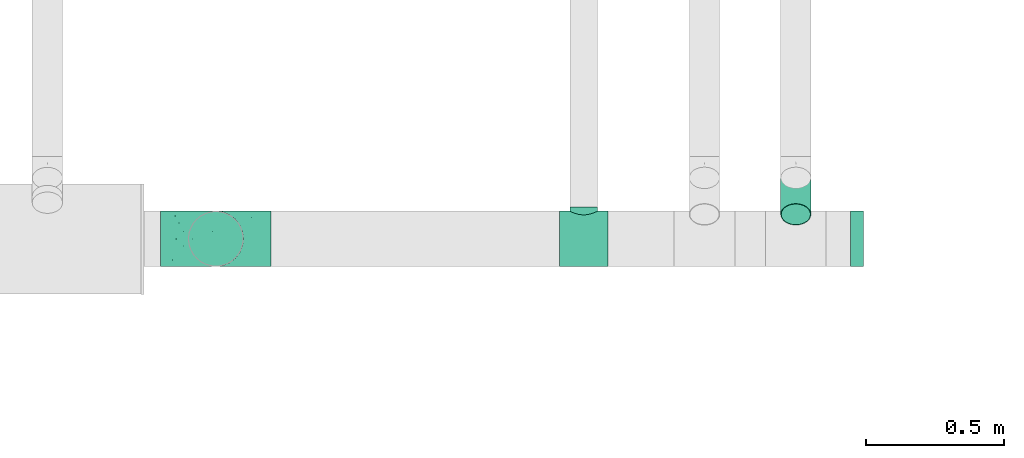
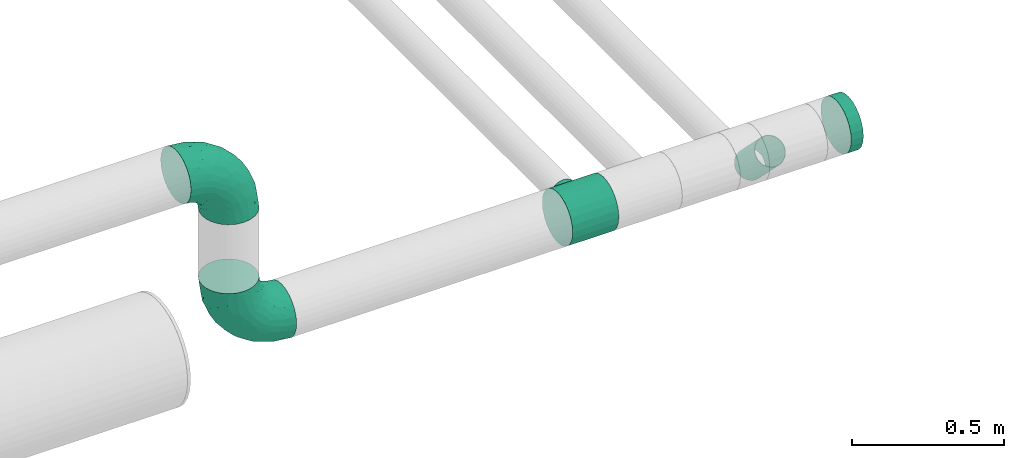
# One storey, part 85 of 91: 4 flow fittings, 1 flow segment.
"""IFC2X3 building model written with IfcOpenShell, lengths in millimetres."""

from ifc_helpers import new_model, entity, si_unit, converted_unit, derived_unit, direction, frame, origin_with_axes, origin_2d_with_axis, place, context, subcontext, project, spatial, hollow_circle, extrude, open_shell, surface_model, source, transform, mapped, material, layer, layer_set, layer_usage, type_object, element, save


model = new_model("IFC2X3")

# Units and contexts
model_context = context("Model", 3, precision=1e-05, world=origin_with_axes(), true_north=direction((0.0, 1.0)))
body_context = subcontext(model_context, "Body", "Model", "MODEL_VIEW")
ifc_project = project(units=[si_unit("AREAUNIT", "SQUARE_METRE"), si_unit("VOLUMEUNIT", "CUBIC_METRE", prefix="DECI"), si_unit("TIMEUNIT", "SECOND"), si_unit("THERMODYNAMICTEMPERATUREUNIT", "DEGREE_CELSIUS"), si_unit("PRESSUREUNIT", "PASCAL"), si_unit("MASSUNIT", "GRAM", prefix="KILO"), si_unit("LENGTHUNIT", "METRE", prefix="MILLI"), si_unit("POWERUNIT", "WATT"), si_unit("ELECTRICCURRENTUNIT", "AMPERE"), si_unit("ELECTRICVOLTAGEUNIT", "VOLT"), derived_unit("VOLUMETRICFLOWRATEUNIT", [(si_unit("VOLUMEUNIT", "CUBIC_METRE", prefix="DECI"), 1), (si_unit("TIMEUNIT", "SECOND"), -1)]), derived_unit("LINEARVELOCITYUNIT", [(si_unit("LENGTHUNIT", "METRE"), 1), (si_unit("TIMEUNIT", "SECOND"), -1)]), derived_unit("MASSDENSITYUNIT", [(si_unit("MASSUNIT", "GRAM", prefix="KILO"), 1), (si_unit("VOLUMEUNIT", "CUBIC_METRE"), -1)]), converted_unit("PLANEANGLEUNIT", "DEGREE", entity("IfcRatioMeasure", 0.01745), si_unit("PLANEANGLEUNIT", "RADIAN"), dimensions=[0, 0, 0, 0, 0, 0, 0])], contexts=[model_context])

# Site, building, storey
site_placement = place(None, origin_with_axes())
site = spatial("IfcSite", under=ifc_project, at=site_placement, CompositionType="ELEMENT")
building_placement = place(site_placement, origin_with_axes())
building = spatial("IfcBuilding", under=site, at=building_placement, Name="mc-building", CompositionType="ELEMENT")
storey_placement = place(building_placement, frame((0.0, 0.0, 8700.0), z_axis=(0.0, 0.0, 1.0), x_axis=(1.0, 0.0, 0.0)))
storey = spatial("IfcBuildingStorey", under=building, at=storey_placement, CompositionType="ELEMENT", Elevation=8700.0)

# Flow fittings
duct_fitting_type_1 = type_object("IfcDuctFittingType", Name="BU", PredefinedType="BEND")
shared_shape_1 = source(origin_with_axes(), body_context, "Body", "SurfaceModel", [
    surface_model("IfcShellBasedSurfaceModel", [(-200.0, 0.0, -100.0), (-200.0, -25.8819, -96.59259), (-200.0, 25.8819, -96.59259), (-200.0, 96.59259, 25.8819), (-200.0, 50.0, -86.60254), (-200.0, 70.71068, -70.71068), (-200.0, 86.60254, -50.0), (-200.0, -100.0, 0.0), (-200.0, -96.59259, 25.8819), (-200.0, -70.71068, -70.71068), (-200.0, -50.0, -86.60254), (-200.0, -96.59259, -25.8819), (-200.0, -86.60254, -50.0), (-200.0, 96.59259, -25.8819), (-200.0, 86.60254, 50.0), (-200.0, 70.71068, 70.71068), (-200.0, 25.8819, 96.59259), (-200.0, 50.0, 86.60254), (-200.0, 0.0, 100.0), (-200.0, -86.60254, 50.0), (-200.0, -70.71068, 70.71068), (-200.0, -25.8819, 96.59259), (-200.0, -50.0, 86.60254), (-200.0, 100.0, 0.0), (-25.8819, 200.0, -96.59259), (-100.0, 200.0, 0.0), (0.0, 200.0, -100.0), (-50.0, 200.0, -86.60254), (-70.71068, 200.0, -70.71068), (-86.60254, 200.0, -50.0), (70.71068, 200.0, -70.71068), (96.59259, 200.0, 25.8819), (50.0, 200.0, -86.60254), (25.8819, 200.0, -96.59259), (86.60254, 200.0, -50.0), (96.59259, 200.0, -25.8819), (100.0, 200.0, 0.0), (-96.59259, 200.0, -25.8819), (-96.59259, 200.0, 25.8819), (-86.60254, 200.0, 50.0), (-70.71068, 200.0, 70.71068), (-50.0, 200.0, 86.60254), (-25.8819, 200.0, 96.59259), (25.8819, 200.0, 96.59259), (86.60254, 200.0, 50.0), (70.71068, 200.0, 70.71068), (50.0, 200.0, 86.60254), (0.0, 200.0, 100.0), (-142.1863, 34.77791, 96.8362), (-155.49581, 5.01442, 100.0), (-113.22325, 19.80623, 100.0), (-109.64128, 126.06035, 55.41027), (-127.7969, 106.94054, 56.92737), (-108.17632, 108.17633, 71.2751), (-5.01442, 155.49581, 100.0), (-34.77791, 142.1863, 96.8362), (-43.63371, 75.30204, 100.0), (-19.80623, 113.22325, 100.0), (-46.75022, 103.70679, 98.17674), (-105.76308, 145.45873, 41.20143), (-106.50542, 158.55613, 21.17876), (-116.75715, 139.59497, 23.7043), (-76.22447, 76.22447, 96.8362), (-103.70679, 46.75022, 98.17674), (-114.94632, 64.63784, 91.59278), (-75.30204, 43.63371, 100.0), (-142.46407, 59.86008, 87.44653), (-163.93033, 65.63323, 79.33534), (-167.52709, 45.64134, 90.63041), (-172.10018, 96.06756, 38.26834), (-178.95596, 81.18455, 60.87614), (-179.46048, 100.38668, 18.40776), (-158.55613, 106.50542, 21.17875), (-141.22148, 119.0983, 0.0), (-169.09831, 104.89435, 0.0), (-81.18455, 178.95596, 60.87614), (-65.63324, 163.93033, 79.33534), (-104.89435, 169.09831, 0.0), (-100.38668, 179.46048, 18.40776), (-88.58406, 153.67022, 60.87614), (-64.63783, 114.94632, 91.59278), (-91.80746, 91.80747, 88.27056), (-145.45873, 105.76308, 41.20143), (-54.39722, 146.03504, 89.44422), (-38.84531, 172.07069, 93.12307), (-82.00007, 130.61272, 77.56928), (-96.06756, 172.10018, 38.26834), (-124.21477, 124.21477, 37.19946), (-131.29923, 125.23215, 17.4727), (-153.67022, 88.58406, 60.87614), (-130.61272, 82.00007, 77.56928), (-119.0983, 141.22148, 0.0), (-91.80746, 91.80747, -88.27056), (-76.22447, 76.22447, -96.8362), (-114.94632, 64.63784, -91.59278), (-179.46048, 100.38668, -18.40776), (-153.67022, 88.58406, -60.87614), (-178.95596, 81.18455, -60.87614), (-172.10018, 96.06756, -38.26834), (-145.45873, 105.76308, -41.20143), (-158.55613, 106.50542, -21.17875), (-139.59496, 116.75715, -23.7043), (-130.61272, 82.00007, -77.56928), (-163.93033, 65.63323, -79.33534), (-113.22325, 19.80623, -100.0), (-103.70679, 46.75022, -98.17674), (-75.30204, 43.63371, -100.0), (-155.49581, 5.01442, -100.0), (-142.1863, 34.77791, -96.8362), (-146.03504, 54.39722, -89.44422), (-126.06035, 109.64129, -55.41026), (-172.07069, 38.84531, -93.12307), (-88.58406, 153.67022, -60.87614), (-65.63324, 163.93033, -79.33534), (-82.00007, 130.61272, -77.56928), (-64.63783, 114.94632, -91.59278), (-124.21477, 124.21477, -37.19946), (-125.23215, 131.29923, -17.4727), (-108.17632, 108.17633, -71.2751), (-106.94054, 127.7969, -56.92737), (-106.50542, 158.55613, -21.17876), (-96.06756, 172.10018, -38.26834), (-105.76308, 145.45873, -41.20143), (-81.18455, 178.95596, -60.87614), (-46.75022, 103.70679, -98.17674), (-45.64134, 167.52709, -90.63041), (-34.77791, 142.1863, -96.8362), (-100.38668, 179.46048, -18.40776), (-43.63371, 75.30204, -100.0), (-19.80623, 113.22325, -100.0), (-59.86008, 142.46407, -87.44653), (-5.01442, 155.49581, -100.0), (-42.87581, 42.87581, -97.50303), (-141.47291, -94.23558, 0.0), (-116.50611, -84.39122, -26.61078), (94.23558, 141.47291, 0.0), (84.39122, 116.50611, -26.61078), (-116.47212, -5.91045, -97.50303), (-85.19497, -77.16386, 0.0), (51.59507, 147.69073, -82.18155), (57.02262, 66.71881, -44.55719), (73.52561, 132.9866, -57.78389), (-132.9866, -73.52561, -57.78389), (-156.43983, -59.78069, -77.32718), (-120.16413, -31.92556, -89.16023), (-101.69565, -47.84762, -74.56731), (-38.23863, 2.57772, -83.36462), (-7.50246, 45.58943, -88.38606), (-9.62762, 9.62763, -72.16367), (29.45251, 12.38032, -26.61078), (13.95152, 10.52566, -51.3821), (-53.04352, -58.62506, -22.39029), (-66.71882, -57.02262, -44.55719), (-14.06031, -26.62828, -36.38714), (32.21655, 106.7844, -86.47094), (20.531, 60.83223, -79.41579), (13.5103, 109.10636, -94.72405), (-33.32893, -49.44088, 0.0), (-9.18924, -29.5697, -17.17165), (-52.32869, -24.39836, -72.73297), (-30.02684, -26.7489, -55.20209), (-75.13255, -49.60396, -61.18808), (47.84762, 101.69564, -74.56731), (30.71754, 49.49063, -65.60715), (-65.49342, 2.98195, -92.269), (63.30067, 60.45187, -19.92515), (49.44088, 33.32893, 0.0), (12.13203, -12.13203, 0.0), (77.16386, 85.19497, 0.0), (55.95148, 88.67648, -61.16476), (-116.50611, -84.39122, 26.61078), (-42.87581, 42.87581, 97.50303), (-45.58943, 7.50246, 88.38606), (-2.98194, 65.49343, 92.269), (-132.9866, -73.52561, 57.78389), (-147.69074, -51.59508, 82.18155), (84.39122, 116.50611, 26.61078), (-12.38032, -29.45251, 26.61078), (-60.45187, -63.30067, 19.92515), (-101.69565, -47.84762, 74.56731), (-60.83224, -20.53101, 79.41579), (-106.78441, -32.21656, 86.47094), (5.91045, 116.47212, 97.50303), (31.92556, 120.16414, 89.16023), (-2.5777, 38.23864, 83.36462), (59.78069, 156.43983, 77.32718), (73.52561, 132.9866, 57.78389), (-109.10636, -13.5103, 94.72405), (-49.49063, -30.71753, 65.60716), (-66.71882, -57.02262, 44.55719), (-10.52566, -13.95152, 51.3821), (29.56969, 9.18923, 17.17165), (58.62506, 53.04351, 22.39029), (26.62828, 14.06031, 36.38714), (-9.62762, 9.62763, 72.16367), (24.39837, 52.32869, 72.73297), (57.02262, 66.71881, 44.55719), (26.74891, 30.02684, 55.20209), (49.60397, 75.13255, 61.18808), (47.84762, 101.69564, 74.56731), (-88.67648, -55.95148, 61.16476)], [open_shell([[[0, 1, 2]], [[2, 3, 4]], [[5, 3, 6]], [[4, 3, 5]], [[2, 7, 8]], [[9, 7, 10]], [[2, 1, 10]], [[11, 7, 12]], [[9, 12, 7]], [[10, 7, 2]], [[13, 6, 3]], [[14, 3, 2]], [[15, 14, 2]], [[2, 16, 17]], [[17, 15, 2]], [[18, 16, 2]], [[8, 19, 2]], [[19, 20, 2]], [[21, 18, 22]], [[20, 22, 18]], [[2, 20, 18]], [[23, 13, 3]], [[24, 25, 26]], [[27, 25, 24]], [[28, 29, 25]], [[28, 25, 27]], [[30, 26, 31]], [[26, 30, 32]], [[32, 33, 26]], [[30, 31, 34]], [[35, 34, 31]], [[35, 31, 36]], [[25, 29, 37]], [[38, 39, 26]], [[40, 26, 39]], [[41, 42, 26]], [[26, 40, 41]], [[43, 26, 42]], [[26, 44, 31]], [[45, 44, 26]], [[26, 46, 45]], [[46, 26, 43]], [[42, 47, 43]], [[38, 26, 25]], [[48, 49, 50]], [[49, 16, 18]], [[51, 52, 53]], [[54, 42, 55]], [[56, 57, 58]], [[59, 60, 61]], [[58, 62, 56]], [[48, 50, 63]], [[63, 62, 64]], [[63, 50, 65]], [[57, 54, 55]], [[66, 67, 68]], [[69, 14, 70]], [[3, 71, 23]], [[14, 15, 70]], [[72, 73, 74]], [[16, 49, 48]], [[15, 17, 67]], [[39, 75, 40]], [[40, 75, 76]], [[65, 56, 62]], [[77, 60, 78]], [[68, 16, 48]], [[51, 79, 59]], [[80, 58, 55]], [[64, 62, 81]], [[72, 69, 82]], [[76, 83, 84]], [[47, 42, 54]], [[79, 51, 85]], [[55, 83, 80]], [[41, 40, 76]], [[59, 79, 86]], [[87, 61, 88]], [[85, 76, 79]], [[14, 69, 3]], [[89, 67, 90]], [[86, 39, 38]], [[25, 77, 78]], [[79, 75, 86]], [[81, 62, 80]], [[55, 84, 83]], [[68, 67, 17]], [[67, 89, 70]], [[90, 53, 52]], [[59, 61, 87]], [[82, 69, 89]], [[71, 69, 72]], [[62, 63, 65]], [[48, 63, 64]], [[55, 58, 57]], [[62, 58, 80]], [[81, 85, 53]], [[83, 85, 80]], [[66, 90, 67]], [[81, 90, 64]], [[59, 86, 60]], [[51, 59, 87]], [[89, 90, 52]], [[88, 72, 82]], [[78, 60, 86]], [[91, 60, 77]], [[86, 38, 78]], [[25, 78, 38]], [[82, 87, 88]], [[71, 72, 74]], [[23, 71, 74]], [[3, 69, 71]], [[60, 91, 61]], [[88, 91, 73]], [[91, 88, 61]], [[72, 88, 73]], [[52, 87, 82]], [[51, 53, 85]], [[87, 52, 51]], [[89, 52, 82]], [[85, 81, 80]], [[90, 81, 53]], [[86, 75, 39]], [[76, 75, 79]], [[67, 70, 15]], [[69, 70, 89]], [[55, 42, 84]], [[85, 83, 76]], [[42, 41, 84]], [[76, 84, 41]], [[16, 68, 17]], [[66, 48, 64]], [[48, 66, 68]], [[90, 66, 64]], [[92, 93, 94]], [[23, 74, 95]], [[96, 97, 98]], [[99, 100, 101]], [[102, 103, 96]], [[96, 98, 99]], [[98, 6, 13]], [[104, 105, 106]], [[105, 93, 106]], [[5, 97, 103]], [[107, 0, 2]], [[108, 109, 94]], [[110, 96, 99]], [[111, 103, 109]], [[112, 113, 114]], [[94, 105, 108]], [[93, 92, 115]], [[107, 2, 108]], [[5, 103, 4]], [[5, 6, 97]], [[116, 101, 117]], [[114, 118, 119]], [[113, 28, 27]], [[120, 121, 122]], [[123, 29, 28]], [[124, 93, 115]], [[125, 24, 126]], [[121, 29, 123]], [[37, 127, 25]], [[104, 107, 108]], [[96, 110, 102]], [[108, 111, 109]], [[110, 119, 118]], [[106, 93, 128]], [[126, 129, 124]], [[130, 113, 125]], [[29, 121, 37]], [[24, 131, 126]], [[24, 26, 131]], [[129, 126, 131]], [[129, 128, 124]], [[113, 112, 123]], [[99, 101, 116]], [[77, 120, 91]], [[125, 113, 27]], [[74, 100, 95]], [[122, 121, 112]], [[127, 121, 120]], [[108, 105, 104]], [[93, 105, 94]], [[93, 124, 128]], [[126, 124, 115]], [[92, 102, 118]], [[109, 102, 94]], [[130, 114, 113]], [[92, 114, 115]], [[99, 98, 100]], [[110, 99, 116]], [[112, 114, 119]], [[117, 120, 122]], [[95, 100, 98]], [[73, 100, 74]], [[98, 13, 95]], [[23, 95, 13]], [[122, 116, 117]], [[127, 120, 77]], [[25, 127, 77]], [[37, 121, 127]], [[100, 73, 101]], [[117, 73, 91]], [[73, 117, 101]], [[120, 117, 91]], [[119, 116, 122]], [[110, 118, 102]], [[116, 119, 110]], [[112, 119, 122]], [[102, 92, 94]], [[114, 92, 118]], [[98, 97, 6]], [[103, 97, 96]], [[113, 123, 28]], [[121, 123, 112]], [[108, 2, 111]], [[102, 109, 103]], [[2, 4, 111]], [[103, 111, 4]], [[24, 125, 27]], [[130, 126, 115]], [[126, 130, 125]], [[114, 130, 115]], [[104, 106, 132]], [[133, 11, 134]], [[35, 135, 136]], [[137, 0, 107]], [[138, 133, 134]], [[33, 32, 139]], [[106, 128, 132]], [[137, 104, 132]], [[136, 140, 141]], [[12, 9, 142]], [[133, 7, 11]], [[143, 144, 145]], [[146, 147, 148]], [[142, 134, 12]], [[149, 150, 140]], [[134, 151, 138]], [[136, 34, 35]], [[151, 152, 153]], [[9, 143, 142]], [[9, 10, 143]], [[154, 155, 147]], [[30, 141, 139]], [[129, 156, 132]], [[12, 134, 11]], [[131, 156, 129]], [[157, 151, 158]], [[159, 160, 161]], [[156, 131, 33]], [[162, 155, 154]], [[163, 155, 162]], [[137, 144, 1]], [[0, 137, 1]], [[163, 140, 150]], [[33, 131, 26]], [[144, 137, 164]], [[141, 162, 139]], [[34, 141, 30]], [[165, 140, 136]], [[166, 167, 149]], [[158, 151, 153]], [[165, 136, 168]], [[147, 132, 156]], [[104, 137, 107]], [[36, 135, 35]], [[129, 132, 128]], [[136, 135, 168]], [[165, 166, 149]], [[148, 159, 146]], [[144, 164, 146]], [[164, 137, 132]], [[153, 160, 150]], [[132, 147, 164]], [[1, 144, 10]], [[136, 141, 34]], [[162, 169, 163]], [[161, 142, 145]], [[134, 142, 152]], [[153, 150, 149]], [[163, 150, 148]], [[149, 167, 158]], [[160, 153, 152]], [[138, 151, 157]], [[134, 152, 151]], [[161, 160, 152]], [[148, 150, 160]], [[142, 161, 152]], [[159, 161, 145]], [[159, 145, 144]], [[160, 159, 148]], [[144, 146, 159]], [[147, 146, 164]], [[149, 158, 153]], [[157, 158, 167]], [[155, 148, 147]], [[162, 141, 169]], [[148, 155, 163]], [[154, 147, 156]], [[33, 154, 156]], [[139, 162, 154]], [[33, 139, 154]], [[30, 139, 32]], [[141, 140, 169]], [[140, 163, 169]], [[144, 143, 10]], [[142, 143, 145]], [[166, 165, 168]], [[140, 165, 149]], [[170, 133, 138]], [[133, 8, 7]], [[50, 171, 65]], [[171, 172, 173]], [[20, 174, 175]], [[168, 135, 176]], [[157, 167, 177]], [[170, 138, 178]], [[21, 22, 175]], [[157, 177, 178]], [[179, 180, 181]], [[174, 179, 175]], [[47, 182, 43]], [[183, 173, 184]], [[170, 19, 8]], [[49, 18, 21]], [[45, 185, 186]], [[187, 50, 49]], [[21, 187, 49]], [[188, 180, 179]], [[173, 182, 171]], [[188, 189, 190]], [[178, 189, 170]], [[172, 171, 187]], [[19, 174, 20]], [[191, 192, 193]], [[177, 190, 189]], [[168, 176, 192]], [[135, 36, 31]], [[194, 195, 184]], [[181, 180, 172]], [[44, 186, 176]], [[184, 172, 194]], [[196, 193, 192]], [[57, 182, 54]], [[46, 185, 45]], [[56, 182, 57]], [[171, 56, 65]], [[166, 192, 191]], [[195, 197, 198]], [[135, 31, 176]], [[171, 182, 56]], [[170, 189, 174]], [[54, 182, 47]], [[8, 133, 170]], [[171, 50, 187]], [[44, 45, 186]], [[193, 197, 190]], [[44, 176, 31]], [[43, 182, 183]], [[185, 183, 199]], [[183, 182, 173]], [[43, 183, 46]], [[170, 174, 19]], [[179, 200, 188]], [[198, 186, 199]], [[176, 186, 196]], [[193, 190, 177]], [[188, 190, 194]], [[177, 167, 191]], [[197, 193, 196]], [[168, 192, 166]], [[176, 196, 192]], [[198, 197, 196]], [[194, 190, 197]], [[186, 198, 196]], [[195, 198, 199]], [[195, 199, 183]], [[197, 195, 194]], [[183, 184, 195]], [[172, 184, 173]], [[177, 191, 193]], [[166, 191, 167]], [[180, 194, 172]], [[179, 174, 200]], [[194, 180, 188]], [[181, 172, 187]], [[21, 181, 187]], [[175, 179, 181]], [[21, 175, 181]], [[20, 175, 22]], [[174, 189, 200]], [[189, 188, 200]], [[183, 185, 46]], [[186, 185, 199]], [[157, 178, 138]], [[189, 178, 177]]])]),
])
for number, where, z_axis, x_axis, name in (
    (1, (34621.56389, 10080.96985, 1344.0), (0.0, 1.0, 0.0), (1.0, 0.0, 0.0), "BU"),
    (2, (34621.56389, 10080.96985, 668.0), (0.0, -1.0, 0.0), (0.0, 0.0, -1.0), "BU"),
):
    element("IfcFlowFitting", number, at=place(storey_placement, frame(where, z_axis=z_axis, x_axis=x_axis)), inside=storey, type_object=duct_fitting_type_1, Name=name, context=body_context, shape_type="MappedRepresentation", body=[
        mapped(shared_shape_1, transform((0.0, 0.0, 0.0), scale=1.0)),
    ])
duct_fitting_type_2 = type_object("IfcDuctFittingType", PredefinedType="JUNCTION")
shared_shape_2 = source(origin_with_axes(), body_context, "Body", "SurfaceModel", [
    surface_model("IfcShellBasedSurfaceModel", [(0.0, -115.0, -50.0), (12.94095, -115.0, -48.29629), (-12.94095, -115.0, -48.29629), (-48.29629, -115.0, 12.94095), (-25.0, -115.0, -43.30127), (-35.35534, -115.0, -35.35534), (-43.30127, -115.0, -25.0), (50.0, -115.0, 0.0), (48.29629, -115.0, 12.94095), (35.35534, -115.0, -35.35534), (25.0, -115.0, -43.30127), (48.29629, -115.0, -12.94095), (43.30127, -115.0, -25.0), (-48.29629, -115.0, -12.94095), (-43.30127, -115.0, 25.0), (-35.35534, -115.0, 35.35534), (-25.0, -115.0, 43.30127), (12.94095, -115.0, 48.29629), (-12.94095, -115.0, 48.29629), (43.30127, -115.0, 25.0), (35.35534, -115.0, 35.35534), (25.0, -115.0, 43.30127), (0.0, -115.0, 50.0), (-50.0, -115.0, 0.0), (0.0, -86.60254, 50.0), (-11.29508, -87.33601, 48.70751), (-21.87117, -89.3216, 44.96279), (-31.22241, -92.05889, 39.05331), (-39.01556, -94.98534, 31.26958), (-44.95251, -97.57421, 21.89228), (-48.70979, -99.36118, 11.28523), (-50.0, -100.0, 0.0), (-44.94438, -97.57047, -21.90897), (-39.00437, -94.98074, -31.28353), (-48.70578, -99.35921, -11.30254), (-31.2088, -92.05427, -39.06419), (-21.85584, -89.31785, -44.97024), (-11.27892, -87.33392, -48.71125), (0.0, -86.60254, -50.0), (11.29508, -87.33601, -48.70751), (21.87117, -89.3216, -44.96279), (31.22241, -92.05889, -39.05331), (39.01556, -94.98534, -31.26958), (44.95251, -97.57421, -21.89228), (48.70979, -99.36118, -11.28523), (50.0, -100.0, 0.0), (44.95251, -97.57421, 21.89228), (39.01556, -94.98534, 31.26958), (48.70979, -99.36118, 11.28523), (31.22241, -92.05889, 39.05331), (21.87117, -89.3216, 44.96279), (11.29508, -87.33601, 48.70751), (-87.5, 0.0, -100.0), (-87.5, -25.8819, -96.59259), (-87.5, 25.8819, -96.59259), (-87.5, 96.59259, 25.8819), (-87.5, 50.0, -86.60254), (-87.5, 86.60254, -50.0), (-87.5, 70.71068, -70.71068), (-87.5, -100.0, 0.0), (-87.5, -96.59259, 25.8819), (-87.5, -70.71068, -70.71068), (-87.5, -50.0, -86.60254), (-87.5, -96.59259, -25.8819), (-87.5, -86.60254, -50.0), (-87.5, 96.59259, -25.8819), (-87.5, 86.60254, 50.0), (-87.5, 70.71068, 70.71068), (-87.5, 50.0, 86.60254), (-87.5, 25.8819, 96.59259), (-87.5, 0.0, 100.0), (-87.5, -86.60254, 50.0), (-87.5, -70.71068, 70.71068), (-87.5, -25.8819, 96.59259), (-87.5, -50.0, 86.60254), (-87.5, 100.0, 0.0), (87.5, 25.8819, -96.59259), (87.5, 100.0, 0.0), (87.5, 0.0, -100.0), (87.5, 50.0, -86.60254), (87.5, 70.71068, -70.71068), (87.5, 86.60254, -50.0), (87.5, -70.71068, -70.71068), (87.5, -96.59259, 25.8819), (87.5, -50.0, -86.60254), (87.5, -25.8819, -96.59259), (87.5, -86.60254, -50.0), (87.5, -96.59259, -25.8819), (87.5, -100.0, 0.0), (87.5, 96.59259, -25.8819), (87.5, 96.59259, 25.8819), (87.5, 86.60254, 50.0), (87.5, 70.71068, 70.71068), (87.5, 25.8819, 96.59259), (87.5, 50.0, 86.60254), (87.5, -25.8819, 96.59259), (87.5, -70.71068, 70.71068), (87.5, -86.60254, 50.0), (87.5, -50.0, 86.60254), (87.5, 0.0, 100.0), (-87.5, -98.29629, -12.94095), (87.5, -91.59756, -37.94095), (-87.5, -91.59756, -37.94095), (87.5, -98.29629, -12.94095), (87.5, -98.29629, 12.94095), (87.5, -91.59756, 37.94095), (-87.5, -98.29629, 12.94095), (-87.5, -91.59756, 37.94095)], [open_shell([[[0, 1, 2]], [[2, 3, 4]], [[5, 3, 6]], [[4, 3, 5]], [[2, 7, 8]], [[9, 7, 10]], [[1, 10, 7]], [[11, 7, 12]], [[9, 12, 7]], [[7, 2, 1]], [[13, 6, 3]], [[14, 3, 2]], [[15, 14, 2]], [[16, 2, 17]], [[16, 15, 2]], [[16, 17, 18]], [[2, 8, 19]], [[2, 19, 20]], [[20, 21, 2]], [[17, 2, 21]], [[17, 22, 18]], [[23, 13, 3]], [[22, 24, 25]], [[18, 25, 26]], [[22, 25, 18]], [[16, 27, 15]], [[16, 18, 26]], [[27, 16, 26]], [[28, 29, 14]], [[30, 31, 23]], [[29, 30, 3]], [[15, 28, 14]], [[3, 14, 29]], [[23, 3, 30]], [[28, 15, 27]], [[32, 33, 6]], [[34, 32, 13]], [[31, 34, 23]], [[23, 34, 13]], [[32, 6, 13]], [[33, 5, 6]], [[4, 35, 36]], [[36, 37, 2]], [[38, 0, 37]], [[4, 5, 35]], [[0, 2, 37]], [[4, 36, 2]], [[35, 5, 33]], [[0, 38, 39]], [[1, 39, 40]], [[0, 39, 1]], [[10, 41, 9]], [[10, 1, 40]], [[41, 10, 40]], [[42, 43, 12]], [[44, 45, 7]], [[43, 44, 11]], [[9, 42, 12]], [[11, 12, 43]], [[7, 11, 44]], [[42, 9, 41]], [[46, 47, 19]], [[48, 46, 8]], [[45, 48, 7]], [[7, 48, 8]], [[46, 19, 8]], [[47, 20, 19]], [[21, 49, 50]], [[50, 51, 17]], [[24, 22, 51]], [[20, 49, 21]], [[17, 21, 50]], [[22, 17, 51]], [[49, 20, 47]], [[52, 53, 54]], [[54, 55, 56]], [[57, 58, 55]], [[55, 58, 56]], [[54, 59, 60]], [[61, 59, 62]], [[54, 53, 62]], [[63, 59, 64]], [[61, 64, 59]], [[62, 59, 54]], [[65, 57, 55]], [[66, 55, 54]], [[54, 67, 66]], [[68, 54, 69]], [[68, 67, 54]], [[70, 69, 54]], [[71, 72, 54]], [[54, 60, 71]], [[73, 70, 74]], [[54, 72, 74]], [[74, 70, 54]], [[75, 65, 55]], [[76, 77, 78]], [[79, 77, 76]], [[77, 80, 81]], [[77, 79, 80]], [[82, 78, 83]], [[78, 84, 85]], [[78, 82, 84]], [[86, 83, 87]], [[83, 86, 82]], [[88, 87, 83]], [[77, 81, 89]], [[90, 91, 78]], [[91, 92, 78]], [[93, 78, 94]], [[78, 92, 94]], [[78, 93, 95]], [[78, 96, 97]], [[83, 78, 97]], [[78, 98, 96]], [[95, 98, 78]], [[93, 99, 95]], [[90, 78, 77]], [[69, 99, 93]], [[68, 93, 94]], [[70, 99, 69]], [[69, 93, 68]], [[94, 67, 68]], [[94, 92, 67]], [[55, 91, 90]], [[75, 90, 77]], [[92, 66, 67]], [[92, 91, 66]], [[66, 91, 55]], [[90, 75, 55]], [[89, 81, 65]], [[77, 89, 65]], [[65, 75, 77]], [[57, 65, 81]], [[81, 58, 57]], [[81, 80, 58]], [[54, 79, 76]], [[52, 76, 78]], [[80, 56, 58]], [[80, 79, 56]], [[56, 79, 54]], [[76, 52, 54]], [[85, 53, 78]], [[84, 62, 85]], [[82, 86, 38]], [[34, 59, 100]], [[39, 38, 86]], [[40, 101, 41]], [[84, 82, 61]], [[82, 38, 61]], [[85, 62, 53]], [[53, 52, 78]], [[37, 36, 64]], [[33, 102, 35]], [[61, 38, 64]], [[35, 102, 36]], [[61, 62, 84]], [[38, 37, 64]], [[39, 86, 40]], [[101, 42, 41]], [[40, 86, 101]], [[42, 87, 43]], [[88, 45, 44]], [[87, 103, 43]], [[44, 103, 88]], [[43, 103, 44]], [[63, 102, 33]], [[63, 33, 32]], [[102, 64, 36]], [[100, 63, 32]], [[31, 59, 34]], [[100, 32, 34]], [[101, 87, 42]], [[45, 88, 48]], [[104, 83, 46]], [[46, 83, 47]], [[46, 48, 104]], [[47, 83, 105]], [[97, 50, 105]], [[31, 30, 59]], [[59, 30, 106]], [[27, 107, 28]], [[60, 106, 29]], [[60, 29, 28]], [[107, 60, 28]], [[50, 97, 51]], [[50, 49, 105]], [[24, 51, 97]], [[29, 106, 30]], [[98, 95, 73]], [[74, 96, 98]], [[24, 97, 96]], [[70, 95, 99]], [[25, 24, 71]], [[48, 88, 104]], [[71, 107, 26]], [[71, 26, 25]], [[24, 72, 71]], [[26, 107, 27]], [[24, 96, 72]], [[96, 74, 72]], [[73, 74, 98]], [[95, 70, 73]], [[47, 105, 49]]])]),
])
flow_fitting_1_placement = place(storey_placement, frame((35954.21103, 10080.96985, 668.0), z_axis=(0.0, 0.0, 1.0), x_axis=(-1.0, 0.0, 0.0)))
element("IfcFlowFitting", 3, at=flow_fitting_1_placement, inside=storey, type_object=duct_fitting_type_2, context=body_context, shape_type="MappedRepresentation", body=[
    mapped(shared_shape_2, transform((0.0, 0.0, 0.0), scale=1.0)),
])
duct_fitting_type_3 = type_object("IfcDuctFittingType", Name="EPF", PredefinedType="OBSTRUCTION")
shared_shape_3 = source(origin_with_axes(), body_context, "Body", "SurfaceModel", [
    surface_model("IfcShellBasedSurfaceModel", [(0.0, 50.0, -86.60254), (0.0, 25.8819, -96.59259), (0.0, 0.0, -100.0), (0.0, 70.71068, -70.71068), (0.0, 100.0, 0.0), (0.0, 86.60254, -50.0), (0.0, -70.71068, 70.71068), (0.0, -96.59259, -25.8819), (0.0, -50.0, -86.60254), (0.0, -70.71068, -70.71068), (0.0, -25.8819, -96.59259), (0.0, -86.60254, -50.0), (0.0, -100.0, 0.0), (0.0, -96.59259, 25.8819), (0.0, 96.59259, -25.8819), (0.0, 86.60254, 50.0), (0.0, 96.59259, 25.8819), (0.0, 70.71068, 70.71068), (0.0, 50.0, 86.60254), (0.0, 25.8819, 96.59259), (0.0, 0.0, 100.0), (0.0, -86.60254, 50.0), (0.0, -50.0, 86.60254), (0.0, -25.8819, 96.59259), (46.0, 25.8819, -96.59259), (46.0, 50.0, 86.60254), (46.0, 0.0, -100.0), (46.0, 70.71068, -70.71068), (46.0, 50.0, -86.60254), (46.0, 70.71068, 70.71068), (46.0, 86.60254, -50.0), (46.0, -100.0, 0.0), (46.0, -50.0, 86.60254), (46.0, -50.0, -86.60254), (46.0, -70.71068, -70.71068), (46.0, -25.8819, -96.59259), (46.0, -86.60254, -50.0), (46.0, -96.59259, -25.8819), (46.0, 86.60254, 50.0), (46.0, 96.59259, -25.8819), (46.0, 96.59259, 25.8819), (46.0, 25.8819, 96.59259), (46.0, -25.8819, 96.59259), (46.0, -86.60254, 50.0), (46.0, -96.59259, 25.8819), (46.0, -70.71068, 70.71068), (46.0, 0.0, 100.0), (46.0, 100.0, 0.0)], [open_shell([[[0, 1, 2]], [[3, 0, 2]], [[4, 5, 2]], [[3, 2, 5]], [[6, 2, 7]], [[8, 9, 2]], [[2, 10, 8]], [[11, 7, 9]], [[2, 9, 7]], [[12, 13, 7]], [[5, 4, 14]], [[15, 16, 4]], [[2, 17, 15]], [[18, 2, 19]], [[18, 17, 2]], [[2, 20, 19]], [[13, 21, 7]], [[7, 21, 6]], [[22, 23, 2]], [[22, 2, 6]], [[23, 20, 2]], [[4, 2, 15]], [[24, 25, 26]], [[27, 24, 28]], [[29, 24, 30]], [[30, 24, 27]], [[31, 26, 32]], [[33, 31, 34]], [[31, 33, 35]], [[36, 31, 37]], [[31, 36, 34]], [[35, 26, 31]], [[38, 30, 39]], [[40, 38, 39]], [[38, 29, 30]], [[25, 41, 26]], [[24, 29, 25]], [[26, 41, 42]], [[31, 43, 44]], [[31, 45, 43]], [[45, 31, 32]], [[42, 32, 26]], [[41, 46, 42]], [[40, 39, 47]], [[20, 46, 41]], [[19, 41, 25]], [[20, 41, 19]], [[18, 29, 17]], [[18, 19, 25]], [[29, 18, 25]], [[15, 38, 40]], [[16, 40, 47]], [[17, 38, 15]], [[16, 15, 40]], [[4, 16, 47]], [[38, 17, 29]], [[4, 47, 39]], [[14, 39, 30]], [[4, 39, 14]], [[5, 27, 3]], [[5, 14, 30]], [[27, 5, 30]], [[0, 28, 24]], [[1, 24, 26]], [[3, 28, 0]], [[1, 0, 24]], [[2, 1, 26]], [[28, 3, 27]], [[2, 26, 35]], [[10, 35, 33]], [[2, 35, 10]], [[8, 34, 9]], [[8, 10, 33]], [[34, 8, 33]], [[11, 36, 37]], [[12, 37, 31]], [[9, 36, 11]], [[7, 11, 37]], [[12, 7, 37]], [[36, 9, 34]], [[12, 31, 44]], [[13, 44, 43]], [[12, 44, 13]], [[21, 45, 6]], [[21, 13, 43]], [[45, 21, 43]], [[22, 32, 42]], [[23, 42, 46]], [[6, 32, 22]], [[23, 22, 42]], [[20, 23, 46]], [[32, 6, 45]]])]),
])
flow_fitting_2_placement = place(storey_placement, frame((36921.56389, 10080.96985, 668.0), z_axis=(0.0, 0.0, 1.0), x_axis=(1.0, 0.0, 0.0)))
element("IfcFlowFitting", 4, at=flow_fitting_2_placement, inside=storey, type_object=duct_fitting_type_3, context=body_context, shape_type="MappedRepresentation", body=[
    mapped(shared_shape_3, transform((0.0, 0.0, 0.0), scale=1.0)),
])

# Flow segment
ifc_material = material(Name="FZ1")
ifc_layer = layer(ifc_material, 0.0)
ifc_layer_set = layer_set([ifc_layer], Name="FZ1")
ifc_layer_usage = layer_usage(ifc_layer_set, "AXIS1", "POSITIVE", 0.0)
duct_segment_type = type_object("IfcDuctSegmentType", PredefinedType="RIGIDSEGMENT")
shared_shape_4 = source(origin_with_axes(), body_context, "Body", "SweptSolid", [
    extrude(hollow_circle(Radius=55.0, WallThickness=2.0, at=origin_2d_with_axis()), frame((0.0, 0.0, 0.0), z_axis=(1.0, 0.0, 0.0), x_axis=(0.0, 1.0, 0.0)), (0.0, 0.0, 1.0), 187.2),
])
flow_segment_placement = place(storey_placement, frame((36722.77222, 10169.3582, 579.61165), z_axis=(0.0, -0.707107, -0.707107), x_axis=(0.0, 0.707107, -0.707107)))
element("IfcFlowSegment", 5, at=flow_segment_placement, inside=storey, type_object=duct_segment_type, material=ifc_layer_usage, context=body_context, shape_type="MappedRepresentation", body=[
    mapped(shared_shape_4, transform((0.0, 0.0, 0.0), scale=1.0)),
])

save(model, "model.ifc")
